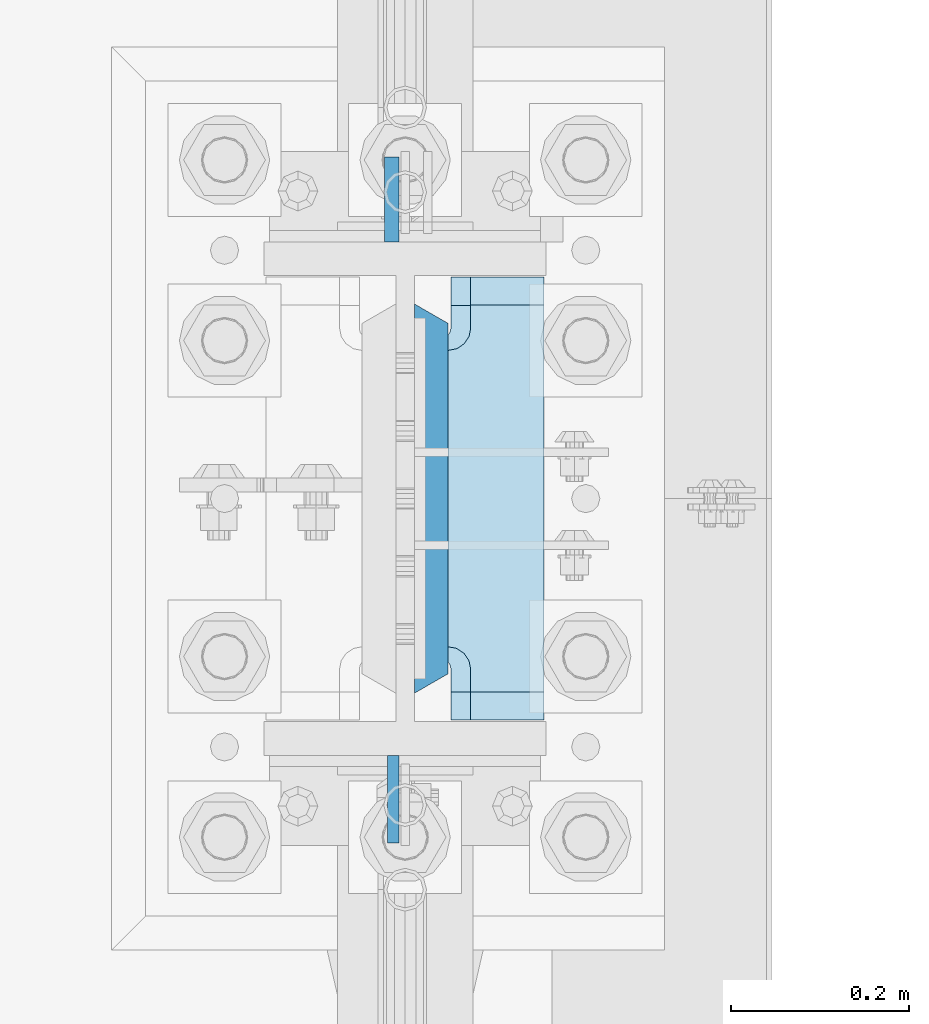
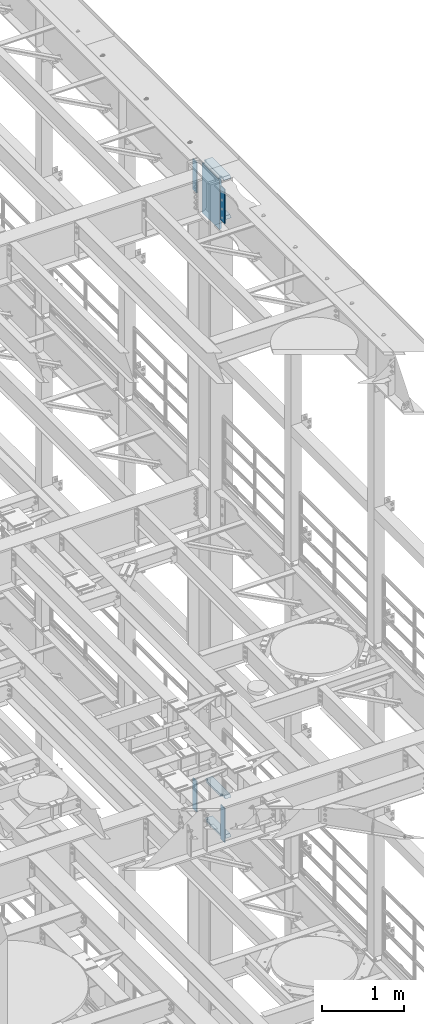
# One storey, part 1815 of 1876: 9 plates, 2 elements without a shape of their own.
"""IFC2X3 building model written with IfcOpenShell, lengths in millimetres."""

from ifc_helpers import new_model, si_unit, frame, origin_with_axes, place, context, subcontext, project, spatial, faceted_brep, material, type_object, element, aggregate, save


model = new_model("IFC2X3")

# Units and contexts
model_context = context("Model", 3, precision=1e-05, world=origin_with_axes())
body_context = subcontext(model_context, "Body", "Model", "MODEL_VIEW")
ifc_project = project(units=[si_unit("LENGTHUNIT", "METRE", prefix="MILLI"), si_unit("AREAUNIT", "SQUARE_METRE"), si_unit("VOLUMEUNIT", "CUBIC_METRE"), si_unit("MASSUNIT", "GRAM", prefix="KILO"), si_unit("TIMEUNIT", "SECOND"), si_unit("PLANEANGLEUNIT", "RADIAN"), si_unit("SOLIDANGLEUNIT", "STERADIAN"), si_unit("THERMODYNAMICTEMPERATUREUNIT", "DEGREE_CELSIUS"), si_unit("LUMINOUSINTENSITYUNIT", "LUMEN")], contexts=[model_context])

# Site, building, storey
site_placement = place(None, origin_with_axes())
site = spatial("IfcSite", under=ifc_project, at=site_placement, CompositionType="ELEMENT")
building_placement = place(site_placement, origin_with_axes())
building = spatial("IfcBuilding", under=site, at=building_placement, Name="Undefined", CompositionType="ELEMENT")
storey_placement = place(building_placement, origin_with_axes())
storey = spatial("IfcBuildingStorey", under=building, at=storey_placement, Name="Undefined", CompositionType="ELEMENT", Elevation=0.0)

# Assembly, plate
assembly_1_placement = place(storey_placement, origin_with_axes())
assembly_1 = element("IfcElementAssembly", 1, at=assembly_1_placement, inside=storey, Name="COLUMN", AssemblyPlace="NOTDEFINED", PredefinedType="RIGID_FRAME")
ifc_material_1 = material(Name="STEEL/A572-50")
plate_type_1 = type_object("IfcPlateType", PredefinedType="NOTDEFINED")
plate_1_placement = place(assembly_1_placement, frame((7606.50699987411, 7331.075, 22501.225), z_axis=(0.0, -1.0, 0.0), x_axis=(0.0, 0.0, -1.0)))
plate_1 = element("IfcPlate", 2, at=plate_1_placement, type_object=plate_type_1, material=ifc_material_1, Name="PLATE", context=body_context, shape_type="Brep", body=[
    faceted_brep([(0.0, -6.35000000000036, 0.0), (0.0, -6.34999999999991, 98.4250030517578), (0.0, 6.34999999999991, 98.4250030517578), (0.0, 6.35000000000036, 0.0), (514.349975585938, -6.35000000000036, 98.4250030517578), (514.349975585938, 6.35000000000036, 98.4250030517578), (514.349975585938, -6.35000000000036, 0.0), (514.349975585938, 6.35000000000036, 0.0)], [[[0, 1, 2, 3]], [[1, 4, 5, 2]], [[4, 6, 7, 5]], [[6, 0, 3, 7]], [[5, 7, 3, 2]], [[6, 4, 1, 0]]]),
])

assembly_2_placement = place(storey_placement, origin_with_axes())
assembly_2 = element("IfcElementAssembly", 3, at=assembly_2_placement, inside=storey, Name="COLUMN", AssemblyPlace="NOTDEFINED", PredefinedType="RIGID_FRAME")
plate_2_placement = place(assembly_2_placement, frame((7606.50699987411, 7331.075, 13255.625), z_axis=(0.0, -1.0, 0.0), x_axis=(0.0, 0.0, -1.0)))
plate_2 = element("IfcPlate", 4, at=plate_2_placement, type_object=plate_type_1, material=ifc_material_1, Name="PLATE", context=body_context, shape_type="Brep", body=[
    faceted_brep([(0.0, -6.35000000000036, 0.0), (0.0, -6.34999999999991, 98.4250030517578), (0.0, 6.34999999999991, 98.4250030517578), (0.0, 6.35000000000036, 0.0), (514.349975585938, -6.35000000000036, 98.4250030517578), (514.349975585938, 6.35000000000036, 98.4250030517578), (514.349975585938, -6.35000000000036, 0.0), (514.349975585938, 6.35000000000036, 0.0)], [[[0, 1, 2, 3]], [[1, 4, 5, 2]], [[4, 6, 7, 5]], [[6, 0, 3, 7]], [[5, 7, 3, 2]], [[6, 4, 1, 0]]]),
])

# Plate
ifc_material_2 = material(Name="STEEL/A572-GR.50")
plate_type_2 = type_object("IfcPlateType", PredefinedType="NOTDEFINED")
plate_3_placement = place(assembly_1_placement, frame((7649.36875, 7400.925, 22523.45), z_axis=(0.0, 1.0, 0.0), x_axis=(0.0, 0.0, -1.0)))
plate_3 = element("IfcPlate", 5, at=plate_3_placement, type_object=plate_type_2, material=ifc_material_2, Name="PLATE", context=body_context, shape_type="Brep", body=[
    faceted_brep([(0.0, -19.0500000000002, 416.152954749452), (742.950012207031, -19.0500000000002, 416.152954749372), (742.950012207031, 19.0500000000002, 438.149993896484), (0.0, 19.0500000000002, 438.149993896484), (742.950012207031, -19.0500000000002, 21.9970452506512), (742.950012207031, 19.0500000000002, 0.0), (-9.09494701772928e-13, 19.05, -1.81898940354586e-12), (0.0, -19.0500000000002, 21.9970452506512)], [[[0, 1, 2, 3]], [[2, 1, 4, 5]], [[3, 2, 5, 6]], [[0, 3, 6, 7]], [[1, 0, 7, 4]], [[6, 5, 4, 7]]]),
])

plate_type_3 = type_object("IfcPlateType", PredefinedType="NOTDEFINED")
plate_4_placement = place(assembly_1_placement, frame((7604.91949987411, 7908.925, 22491.7), z_axis=(0.0, 1.0, 0.0), x_axis=(0.0, 0.0, -1.0)))
plate_4 = element("IfcPlate", 6, at=plate_4_placement, type_object=plate_type_3, material=ifc_material_1, Name="PLATE", context=body_context, shape_type="Brep", body=[
    faceted_brep([(0.0, -7.9375, 0.0), (0.0, -7.9375, 95.25), (0.0, 7.9375, 95.25), (0.0, 7.9375, 0.0), (457.200012207031, -7.9375, 95.25), (457.200012207031, 7.9375, 95.25), (457.200012207031, -7.9375, 0.0), (457.200012207031, 7.9375, 0.0)], [[[0, 1, 2, 3]], [[1, 4, 5, 2]], [[4, 6, 7, 5]], [[6, 0, 3, 7]], [[5, 7, 3, 2]], [[6, 4, 1, 0]]]),
])

ifc_material_3 = material(Name="STEEL/A36")
plate_5_placement = place(assembly_2_placement, frame((7604.91949987411, 7908.925, 13246.1), z_axis=(0.0, 1.0, 0.0), x_axis=(0.0, 0.0, -1.0)))
plate_5 = element("IfcPlate", 7, at=plate_5_placement, type_object=plate_type_3, material=ifc_material_3, Name="PLATE", context=body_context, shape_type="Brep", body=[
    faceted_brep([(0.0, -7.9375, 0.0), (0.0, -7.9375, 95.25), (0.0, 7.9375, 95.25), (0.0, 7.9375, 0.0), (457.200012207031, -7.9375, 95.25), (457.200012207031, 7.9375, 95.25), (457.200012207031, -7.9375, 0.0), (457.200012207031, 7.9375, 0.0)], [[[0, 1, 2, 3]], [[1, 4, 5, 2]], [[4, 6, 7, 5]], [[6, 0, 3, 7]], [[5, 7, 3, 2]], [[6, 4, 1, 0]]]),
])

plate_type_4 = type_object("IfcPlateType", PredefinedType="NOTDEFINED")
plate_6_placement = place(assembly_1_placement, frame((7668.41875, 7869.2375, 21948.775012207), z_axis=(0.0, -1.0, 0.0), x_axis=(1.0, 0.0, 0.0)))
plate_6 = element("IfcPlate", 8, at=plate_6_placement, type_object=plate_type_4, material=ifc_material_1, Name="PLATE", context=body_context, shape_type="Brep", body=[
    faceted_brep([(107.949996948242, -15.875, 498.475006103516), (107.949996948242, 15.875, 467.025007631571), (25.3999996185303, 15.875, 467.025007631571), (25.3999996185303, -15.875, 498.475006103516), (23.4665397733561, -15.875, 431.604843634198), (25.3999996185303, -15.875, 441.325002670288), (25.3999996185303, 15.875, 441.325002670288), (23.4665397733561, 15.875, 431.604843634198), (17.9605119724001, -15.875, 423.36449069789), (17.9605119724001, 15.875, 423.36449069789), (9.72015903609281, -15.875, 417.858462896934), (9.72015903609281, 15.875, 417.858462896934), (0.0, -15.875, 415.925003051758), (0.0, 15.875, 415.925003051758), (0.0, -15.875, 82.5500030517578), (0.0, 15.875, 82.5500030517578), (9.72015903609099, -15.875, 80.616543206582), (9.72015903609099, 15.875, 80.616543206582), (17.9605119723983, -15.875, 75.1105154056258), (17.9605119723983, 15.875, 75.1105154056258), (23.4665397733552, -15.875, 66.8701624693183), (23.4665397733552, 15.875, 66.8701624693183), (25.3999996185303, -15.875, 57.1500034332275), (25.3999996185303, 15.875, 57.1500034332275), (25.3999996185303, 15.875, 31.449998471945), (25.3999996185303, -15.875, 0.0), (107.949996948242, 15.875, 31.449998471945), (107.949996948242, -15.875, 0.0)], [[[0, 1, 2, 3]], [[4, 5, 6, 7]], [[8, 4, 7, 9]], [[10, 8, 9, 11]], [[12, 10, 11, 13]], [[14, 12, 13, 15]], [[16, 14, 15, 17]], [[18, 16, 17, 19]], [[20, 18, 19, 21]], [[22, 20, 21, 23]], [[22, 23, 24, 25]], [[26, 27, 25, 24]], [[5, 4, 8, 10, 12, 14, 16, 18, 20, 22, 25, 27, 0, 3]], [[6, 5, 3, 2]], [[26, 24, 23, 21, 19, 17, 15, 13, 11, 9, 7, 6, 2, 1]], [[27, 26, 1, 0]]]),
])

plate_7_placement = place(assembly_2_placement, frame((7668.41875, 7869.2375, 12703.175012207), z_axis=(0.0, -1.0, 0.0), x_axis=(1.0, 0.0, 0.0)))
plate_7 = element("IfcPlate", 9, at=plate_7_placement, type_object=plate_type_4, material=ifc_material_1, Name="PLATE", context=body_context, shape_type="Brep", body=[
    faceted_brep([(107.949996948242, -15.875, 498.475006103516), (107.949996948242, 15.875, 467.025007631571), (25.3999996185303, 15.875, 467.025007631571), (25.3999996185303, -15.875, 498.475006103516), (23.4665397733561, -15.875, 431.604843634198), (25.3999996185303, -15.875, 441.325002670288), (25.3999996185303, 15.875, 441.325002670288), (23.4665397733561, 15.875, 431.604843634198), (17.9605119724001, -15.875, 423.36449069789), (17.9605119724001, 15.875, 423.36449069789), (9.72015903609281, -15.875, 417.858462896934), (9.72015903609281, 15.875, 417.858462896934), (0.0, -15.875, 415.925003051758), (0.0, 15.875, 415.925003051758), (0.0, -15.875, 82.5500030517578), (0.0, 15.875, 82.5500030517578), (9.72015903609099, -15.875, 80.616543206582), (9.72015903609099, 15.875, 80.616543206582), (17.9605119723983, -15.875, 75.1105154056258), (17.9605119723983, 15.875, 75.1105154056258), (23.4665397733552, -15.875, 66.8701624693183), (23.4665397733552, 15.875, 66.8701624693183), (25.3999996185303, -15.875, 57.1500034332275), (25.3999996185303, 15.875, 57.1500034332275), (25.3999996185303, 15.875, 31.449998471945), (25.3999996185303, -15.875, 0.0), (107.949996948242, 15.875, 31.449998471945), (107.949996948242, -15.875, 0.0)], [[[0, 1, 2, 3]], [[4, 5, 6, 7]], [[8, 4, 7, 9]], [[10, 8, 9, 11]], [[12, 10, 11, 13]], [[14, 12, 13, 15]], [[16, 14, 15, 17]], [[18, 16, 17, 19]], [[20, 18, 19, 21]], [[22, 20, 21, 23]], [[22, 23, 24, 25]], [[26, 27, 25, 24]], [[5, 4, 8, 10, 12, 14, 16, 18, 20, 22, 25, 27, 0, 3]], [[6, 5, 3, 2]], [[26, 24, 23, 21, 19, 17, 15, 13, 11, 9, 7, 6, 2, 1]], [[27, 26, 1, 0]]]),
])

plate_8_placement = place(assembly_2_placement, frame((7668.41875, 7869.2375, 13293.725), z_axis=(0.0, -1.0, 0.0), x_axis=(1.0, 0.0, 0.0)))
plate_8 = element("IfcPlate", 10, at=plate_8_placement, type_object=plate_type_4, material=ifc_material_1, Name="PLATE", context=body_context, shape_type="Brep", body=[
    faceted_brep([(107.949996948242, -15.875, 498.475006103516), (107.949996948242, 15.875, 467.025007631571), (25.3999996185303, 15.875, 467.025007631571), (25.3999996185303, -15.875, 498.475006103516), (23.4665397733561, -15.875, 431.604843634198), (25.3999996185303, -15.875, 441.325002670288), (25.3999996185303, 15.875, 441.325002670288), (23.4665397733561, 15.875, 431.604843634198), (17.9605119724001, -15.875, 423.36449069789), (17.9605119724001, 15.875, 423.36449069789), (9.72015903609281, -15.875, 417.858462896934), (9.72015903609281, 15.875, 417.858462896934), (0.0, -15.875, 415.925003051758), (0.0, 15.875, 415.925003051758), (0.0, -15.875, 82.5500030517578), (0.0, 15.875, 82.5500030517578), (9.72015903609099, -15.875, 80.616543206582), (9.72015903609099, 15.875, 80.616543206582), (17.9605119723983, -15.875, 75.1105154056258), (17.9605119723983, 15.875, 75.1105154056258), (23.4665397733552, -15.875, 66.8701624693183), (23.4665397733552, 15.875, 66.8701624693183), (25.3999996185303, -15.875, 57.1500034332275), (25.3999996185303, 15.875, 57.1500034332275), (25.3999996185303, 15.875, 31.449998471945), (25.3999996185303, -15.875, 0.0), (107.949996948242, 15.875, 31.449998471945), (107.949996948242, -15.875, 0.0)], [[[0, 1, 2, 3]], [[4, 5, 6, 7]], [[8, 4, 7, 9]], [[10, 8, 9, 11]], [[12, 10, 11, 13]], [[14, 12, 13, 15]], [[16, 14, 15, 17]], [[18, 16, 17, 19]], [[20, 18, 19, 21]], [[22, 20, 21, 23]], [[22, 23, 24, 25]], [[26, 27, 25, 24]], [[5, 4, 8, 10, 12, 14, 16, 18, 20, 22, 25, 27, 0, 3]], [[6, 5, 3, 2]], [[26, 24, 23, 21, 19, 17, 15, 13, 11, 9, 7, 6, 2, 1]], [[27, 26, 1, 0]]]),
])

aggregate(assembly_2, [plate_2, plate_5, plate_7, plate_8])

plate_type_5 = type_object("IfcPlateType", PredefinedType="NOTDEFINED")
plate_9_placement = place(assembly_1_placement, frame((7776.36874694824, 7370.7625, 22539.325), z_axis=(0.0, 1.0, 0.0), x_axis=(-1.0, 0.0, 0.0)))
plate_9 = element("IfcPlate", 11, at=plate_9_placement, type_object=plate_type_5, material=ifc_material_1, Name="PLATE", context=body_context, shape_type="Brep", body=[
    faceted_brep([(108.494745348945, -15.875, 66.1302546510551), (108.494745348945, 15.875, 66.1302546510551), (112.614921817099, 15.875, 68.8832685515335), (112.614921817099, -15.875, 68.8832685515335), (105.741731448466, -15.875, 62.0100781829015), (105.741731448466, 15.875, 62.0100781829015), (104.775001525879, -15.875, 57.149998664856), (104.775001525879, 15.875, 57.149998664856), (104.775001525879, -15.875, 0.0), (104.775001525879, 15.875, 31.75), (0.0, -15.875, 0.0), (0.0, 15.875, 31.75), (0.0, -15.875, 498.475006103516), (0.0, 15.875, 466.725006103516), (104.775001525879, -15.875, 498.475006103516), (104.775001525879, 15.875, 466.725006103516), (104.775001525879, -15.875, 441.325001335143), (104.775001525879, 15.875, 441.325001335143), (105.741731448466, -15.875, 436.464921817097), (105.741731448466, 15.875, 436.464921817097), (108.494745348945, -15.875, 432.344745348943), (108.494745348945, 15.875, 432.344745348943), (112.614921817099, -15.875, 429.591731448465), (112.614921817099, 15.875, 429.591731448465), (117.475001335144, -15.875, 428.625001525877), (146.050003051758, -15.875, 428.625001525877), (117.475001335144, 12.6999956131003, 428.625001525877), (114.299996948243, 15.875, 429.256549164917), (114.299996948243, 15.875, 69.218450835082), (117.475001335144, -15.875, 69.8499984741211), (117.475001335144, 12.6999956131003, 69.8499984741211), (146.050003051758, -15.875, 69.8499984741211)], [[[0, 1, 2, 3]], [[4, 5, 1, 0]], [[6, 7, 5, 4]], [[8, 9, 7, 6]], [[10, 11, 9, 8]], [[11, 10, 12, 13]], [[13, 12, 14, 15]], [[14, 16, 17, 15]], [[18, 19, 17, 16]], [[20, 21, 19, 18]], [[22, 23, 21, 20]], [[24, 25, 26]], [[23, 22, 24, 26, 27]], [[2, 1, 5, 7, 9, 11, 13, 15, 17, 19, 21, 23, 27, 28]], [[29, 3, 2, 28, 30]], [[29, 30, 31]], [[24, 22, 20, 18, 16, 14, 12, 10, 8, 6, 4, 0, 3, 29, 31, 25]], [[30, 28, 27, 26, 25, 31]]]),
])

aggregate(assembly_1, [plate_6, plate_3, plate_1, plate_4, plate_9])

save(model, "model.ifc")
